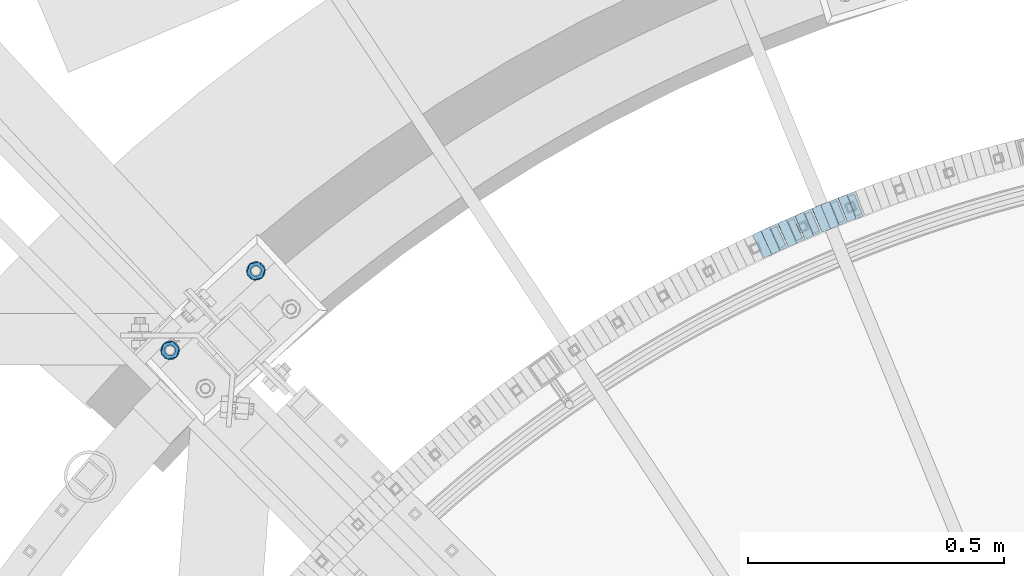
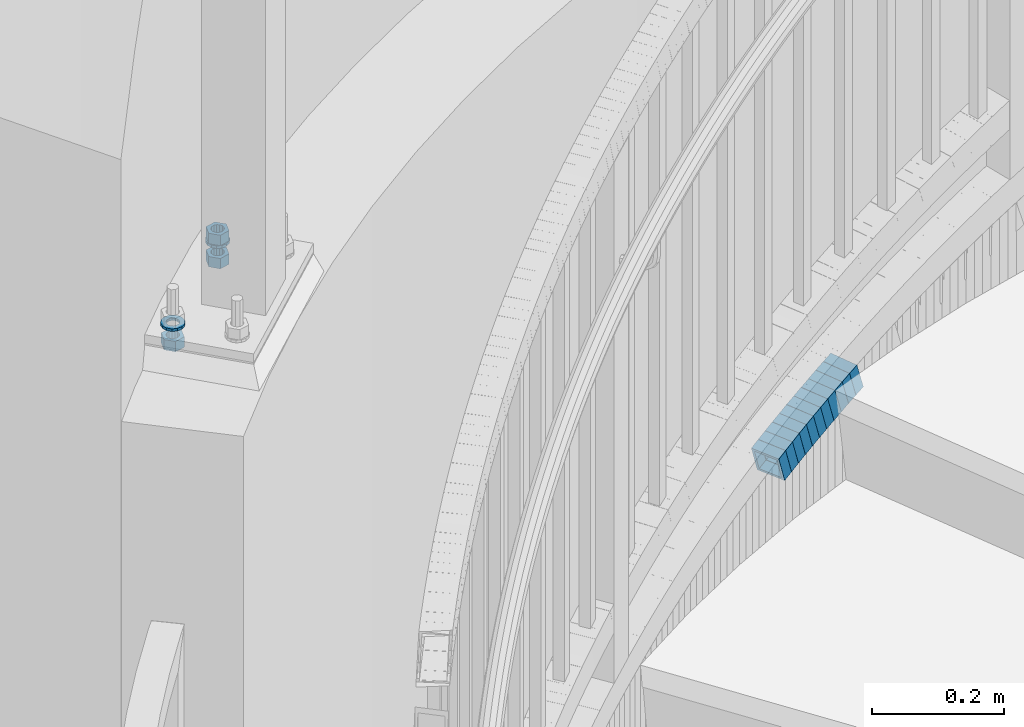
# One storey, part 742 of 975: 16 beams.
"""IFC2X3 building model written with IfcOpenShell, lengths in millimetres."""

import ifcopenshell
import ifcopenshell.guid

model = None  # the IFC model being written
_history = None  # IfcOwnerHistory: only IFC2X3 demands one
_inside = {}  # id of a spatial element -> (the spatial element, [elements in it])
_under = {}  # id of a project, library or spatial element -> (it, [spatial elements below it])
_declared = {}  # id of a project -> (the project, [libraries it declares])
_typed = {}  # id of a type object -> (the type object, [elements of that type])
_made_of = {}  # id of a material, layer set ... -> (it, [elements and type objects made of it])


def new_model(schema):
    """Start an empty IFC model of exactly this schema.

    Asked for "IFC4X3", IfcOpenShell would pick the latest addendum, in which some entities
    have other attributes; the version numbers below select the first issue.
    IFC2X3 requires an IfcOwnerHistory on every rooted entity: one is made here for all.
    """
    global model, _history
    if schema == "IFC4X3":
        model = ifcopenshell.file(schema_version=(4, 3, 0, 0))
    else:
        model = ifcopenshell.file(schema=schema)
    _inside.clear()
    _under.clear()
    _declared.clear()
    _typed.clear()
    _made_of.clear()
    _history = None
    if model.schema == "IFC2X3":
        org = make("IfcOrganization", Name="unknown")
        user = make(
            "IfcPersonAndOrganization",
            ThePerson=make("IfcPerson", FamilyName="unknown"),
            TheOrganization=org,
        )
        app = make(
            "IfcApplication",
            ApplicationDeveloper=org,
            Version="unknown",
            ApplicationFullName="unknown",
            ApplicationIdentifier="unknown",
        )
        _history = make(
            "IfcOwnerHistory",
            OwningUser=user,
            OwningApplication=app,
            ChangeAction="ADDED",
            CreationDate=0,
        )
    return model


def make(cls, **values):
    """One entity of the class cls with the attributes given. An attribute that is None is left unset."""
    return model.create_entity(
        cls, **{name: value for name, value in values.items() if value is not None}
    )


def rooted(cls, **values):
    """An entity with a GlobalId (a new one), such as an element, a storey or a relation."""
    return make(cls, GlobalId=ifcopenshell.guid.new(), OwnerHistory=_history, **values)


def si_unit(unit_type, name, prefix=None):
    """IfcSIUnit, for example si_unit("LENGTHUNIT", "METRE", prefix="MILLI")."""
    return make("IfcSIUnit", UnitType=unit_type, Prefix=prefix, Name=name)


def assignment(units):
    """IfcUnitAssignment: the units of a project."""
    return None if units is None else make("IfcUnitAssignment", Units=units)


def point(xyz):
    """IfcCartesianPoint."""
    return None if xyz is None else make("IfcCartesianPoint", Coordinates=xyz)


def direction(xyz):
    """IfcDirection."""
    return None if xyz is None else make("IfcDirection", DirectionRatios=xyz)


def frame(location, z_axis=None, x_axis=None):
    """IfcAxis2Placement3D, a coordinate frame: its origin and axes. An axis left out is left unset."""
    return make(
        "IfcAxis2Placement3D",
        Location=point(location),
        Axis=direction(z_axis),
        RefDirection=direction(x_axis),
    )


def origin_with_axes():
    """The frame at (0, 0, 0) with the z axis (0, 0, 1) and the x axis (1, 0, 0) written out."""
    return frame((0.0, 0.0, 0.0), z_axis=(0.0, 0.0, 1.0), x_axis=(1.0, 0.0, 0.0))


def place(relative_to, where):
    """IfcLocalPlacement: puts the frame where relative to a parent placement (None: the world)."""
    return make(
        "IfcLocalPlacement", PlacementRelTo=relative_to, RelativePlacement=where
    )


def context(
    kind, dimensions, precision=None, world=None, true_north=None, identifier=None
):
    """IfcGeometricRepresentationContext, for example the 3D "Model" context."""
    return make(
        "IfcGeometricRepresentationContext",
        ContextIdentifier=identifier,
        ContextType=kind,
        CoordinateSpaceDimension=dimensions,
        Precision=precision,
        WorldCoordinateSystem=world,
        TrueNorth=true_north,
    )


def subcontext(parent, identifier, kind, view, scale=None):
    """IfcGeometricRepresentationSubContext, for example "Body" below "Model"."""
    return make(
        "IfcGeometricRepresentationSubContext",
        ContextIdentifier=identifier,
        ContextType=kind,
        ParentContext=parent,
        TargetScale=scale,
        TargetView=view,
    )


def project(units=None, contexts=None):
    """IfcProject with its units and contexts."""
    return rooted(
        "IfcProject",
        Name="project",
        RepresentationContexts=contexts,
        UnitsInContext=assignment(units),
    )


def spatial(cls, under=None, at=None, **own):
    """A site, building, storey or space (cls), placed at a placement, below another one or the project."""
    s = rooted(cls, ObjectPlacement=at, **own)
    if under is not None:
        _under.setdefault(under.id(), (under, []))[1].append(s)
    return s


def faces_of(points, faces, orient=None, outer=None):
    """IfcFace entities. A face is a list of loops; a loop is a list of indices into points, from 0.

    orient and outer hold one flag for each loop. By default every Orientation is true, the
    first loop of a face is its IfcFaceOuterBound and the others are IfcFaceBound.
    """
    made = []
    for i, loops in enumerate(faces):
        bounds = []
        for j, loop in enumerate(loops):
            is_outer = j == 0 if outer is None else outer[i][j]
            bounds.append(
                make(
                    "IfcFaceOuterBound" if is_outer else "IfcFaceBound",
                    Bound=make("IfcPolyLoop", Polygon=[points[k] for k in loop]),
                    Orientation=True if orient is None else orient[i][j],
                )
            )
        made.append(make("IfcFace", Bounds=bounds))
    return made


def faceted_brep(points, faces, orient=None, outer=None, voids=None):
    """IfcFacetedBrep: a solid bounded by flat faces; with voids (closed shells), ...WithVoids."""
    shared = [point(p) for p in points]
    hull = make("IfcClosedShell", CfsFaces=faces_of(shared, faces, orient, outer))
    if voids is None:
        return make("IfcFacetedBrep", Outer=hull)
    return make(
        "IfcFacetedBrepWithVoids",
        Outer=hull,
        Voids=[
            make(cls, CfsFaces=faces_of(shared, fs, o, b)) for cls, fs, o, b in voids
        ],
    )


def shape(context_of_items, identifier, shape_type, items):
    """IfcShapeRepresentation: the items that make up one representation, for example the "Body"."""
    return make(
        "IfcShapeRepresentation",
        ContextOfItems=context_of_items,
        RepresentationIdentifier=identifier,
        RepresentationType=shape_type,
        Items=items,
    )


def material(Name=None, Category=None):
    """IfcMaterial."""
    return make("IfcMaterial", Name=Name, Category=Category)


def made_of(thing, what):
    """Note that an element or type object is made of a material, layer set ...; save() writes the relation."""
    if what is not None:
        _made_of.setdefault(what.id(), (what, []))[1].append(thing)
    return thing


def type_object(cls, material=None, **own):
    """A type object (cls), such as IfcWallType, which elements share."""
    return made_of(rooted(cls, **own), material)


def element(
    cls,
    number,
    at=None,
    inside=None,
    cuts=None,
    type_object=None,
    material=None,
    context=None,
    identifier="Body",
    shape_type=None,
    held_by="IfcProductDefinitionShape",
    body=None,
    shapes=None,
    **own,
):
    """One element of the class cls, such as IfcWall. Its Tag is "e" and its number.

    at: its placement. inside: the storey or other place that contains it. cuts: it is an
    opening in that element (IfcRelVoidsElement). A single representation is given by context,
    identifier, shape_type and body (its items); several are given by shapes. held_by: the class
    of the entity that holds the representations. save() writes the other relations.
    """
    e = rooted(cls, Tag="e%d" % number, ObjectPlacement=at, **own)
    if body is not None:
        shapes = [shape(context, identifier, shape_type, body)]
    if shapes is not None:
        e.Representation = make(held_by, Representations=shapes)
    if inside is not None:
        _inside.setdefault(inside.id(), (inside, []))[1].append(e)
    if cuts is not None:
        rooted(
            "IfcRelVoidsElement", RelatingBuildingElement=cuts, RelatedOpeningElement=e
        )
    if type_object is not None:
        _typed.setdefault(type_object.id(), (type_object, []))[1].append(e)
    return made_of(e, material)


def aggregate(whole, parts):
    """IfcRelAggregates: a whole, such as a stair, and the parts it consists of."""
    return rooted("IfcRelAggregates", RelatingObject=whole, RelatedObjects=parts)


def save(model, path):
    """Write the relations noted so far, then the file.

    IfcRelAggregates (storeys below a building ...), IfcRelContainedInSpatialStructure (elements
    in a storey), IfcRelDefinesByType, IfcRelAssociatesMaterial and IfcRelDeclares: one each for
    every whole, place, type object, material and project.
    """
    for whole, parts in _under.values():
        aggregate(whole, parts)
    for where, things in _inside.values():
        rooted(
            "IfcRelContainedInSpatialStructure",
            RelatedElements=things,
            RelatingStructure=where,
        )
    for kind, things in _typed.values():
        rooted("IfcRelDefinesByType", RelatedObjects=things, RelatingType=kind)
    for what, things in _made_of.values():
        rooted("IfcRelAssociatesMaterial", RelatedObjects=things, RelatingMaterial=what)
    for by, libraries in _declared.values():
        rooted("IfcRelDeclares", RelatingContext=by, RelatedDefinitions=libraries)
    model.write(path)


model = new_model("IFC2X3")

# Units and contexts
model_context = context("Model", 3, precision=1e-05, world=origin_with_axes())
body_context = subcontext(model_context, "Body", "Model", "MODEL_VIEW")
ifc_project = project(units=[si_unit("LENGTHUNIT", "METRE", prefix="MILLI"), si_unit("AREAUNIT", "SQUARE_METRE"), si_unit("VOLUMEUNIT", "CUBIC_METRE"), si_unit("MASSUNIT", "GRAM", prefix="KILO"), si_unit("TIMEUNIT", "SECOND"), si_unit("PLANEANGLEUNIT", "RADIAN"), si_unit("SOLIDANGLEUNIT", "STERADIAN"), si_unit("THERMODYNAMICTEMPERATUREUNIT", "DEGREE_CELSIUS"), si_unit("LUMINOUSINTENSITYUNIT", "LUMEN")], contexts=[model_context])

# Site, building, storey
site_placement = place(None, origin_with_axes())
site = spatial("IfcSite", under=ifc_project, at=site_placement, CompositionType="ELEMENT")
building_placement = place(site_placement, origin_with_axes())
building = spatial("IfcBuilding", under=site, at=building_placement, Name="Undefined", CompositionType="ELEMENT")
storey_placement = place(building_placement, origin_with_axes())
storey = spatial("IfcBuildingStorey", under=building, at=storey_placement, Name="Undefined", CompositionType="ELEMENT", Elevation=0.0)

# Beams
ifc_material_1 = material()
beam_type_1 = type_object("IfcBeamType", Name="HSS2X2X.188_TUBES", PredefinedType="NOTDEFINED")
beam_1_placement = place(storey_placement, frame((33684.4152739988, 6075.29577214784, 698.497322510695), z_axis=(0.374278314232651, -0.927316420373955, 2.41270754486322e-11), x_axis=(-0.883603947282883, -0.356635328114114, -0.303406175097091)))
element("IfcBeam", 1, at=beam_1_placement, inside=storey, type_object=beam_type_1, material=ifc_material_1, Name="WALL", ObjectType="HSS2X2X.188_TUBES", context=body_context, shape_type="Brep", body=[
    faceted_brep([(0.0, 20.6374999999753, -20.6375000000298), (0.0, -20.6375000000153, -20.6375000000153), (18.7853666454903, -20.6375000000535, -20.6375000000326), (18.785366645363, 20.6374999999862, -20.6375000000044), (0.0, -20.6374999999825, 20.6375000000335), (18.785366645352, -20.6375000000007, 20.6374999999989), (0.0, 20.6375000000116, 20.6375000000189), (18.7853666453102, 20.6375000000025, 20.6374999999753), (0.0, 25.3999999999724, -25.4000000000342), (0.0, 25.400000000016, 25.4000000000196), (18.7853666452065, 25.4000000000451, 25.4000000000351), (18.7853666453739, 25.3999999999833, -25.400000000006), (0.0, -25.399999999976, 25.4000000000378), (18.7853666497213, -25.399999993424, 25.3999999995158), (0.0, -25.400000000016, -25.4000000000196), (18.7853666455194, -25.4000000000633, -25.4000000000406)], [[[0, 1, 2, 3]], [[1, 4, 5, 2]], [[4, 6, 7, 5]], [[6, 0, 3, 7]], [[8, 9, 10, 11]], [[9, 12, 13, 10]], [[12, 14, 15, 13]], [[14, 8, 11, 15]], [[13, 15, 11, 10], [5, 7, 3, 2]], [[14, 12, 9, 8], [6, 4, 1, 0]]]),
])
beam_2_placement = place(storey_placement, frame((33701.4372815012, 6081.82035562376, 704.194928636222), z_axis=(0.362715533424743, -0.931899909760916, -1.45439344123588e-10), x_axis=(-0.888059205870413, -0.345651786949592, -0.303110027955799)))
element("IfcBeam", 2, at=beam_2_placement, inside=storey, type_object=beam_type_1, material=ifc_material_1, Name="WALL", ObjectType="HSS2X2X.188_TUBES", context=body_context, shape_type="Brep", body=[
    faceted_brep([(0.0, 20.6374999999753, -20.6375000000298), (0.0, -20.6375000000153, -20.6375000000153), (18.8066477608099, -20.6374999999862, -20.6375000000116), (18.8066477608172, 20.6375000000062, -20.6374999999971), (0.0, -20.6374999999825, 20.6375000000335), (18.8066477608463, -20.6375000000062, 20.6375000000407), (0.0, 20.6375000000116, 20.6375000000189), (18.8066477608536, 20.6374999999844, 20.637500000048), (0.0, 25.3999999999724, -25.4000000000342), (0.0, 25.400000000016, 25.4000000000196), (18.8066477608591, 25.3999999999814, 25.400000000056), (18.8066477608154, 25.4000000000051, -25.4000000000015), (0.0, -25.399999999976, 25.4000000000378), (18.8066477608518, -25.4000000000087, 25.4000000000451), (0.0, -25.400000000016, -25.4000000000196), (18.8066477608081, -25.3999999999851, -25.4000000000196)], [[[0, 1, 2, 3]], [[1, 4, 5, 2]], [[4, 6, 7, 5]], [[6, 0, 3, 7]], [[8, 9, 10, 11]], [[9, 12, 13, 10]], [[12, 14, 15, 13]], [[14, 8, 11, 15]], [[13, 15, 11, 10], [5, 7, 3, 2]], [[14, 12, 9, 8], [6, 4, 1, 0]]]),
])
for number, where, z_axis, x_axis, name in (
    (3, (33651.1781848569, 6061.82399622755, 687.031840070011), (0.379066925584048, -0.925369259230205, -2.88005594484275e-10), (-0.880491033946497, -0.360683073978141, -0.307641445981368), "WALL"),
    (4, (33667.77818525, 6068.6239961446, 692.831839940135), (0.379066925584048, -0.925369259230205, -2.88005594484275e-10), (-0.880491033946497, -0.360683073978141, -0.307641445981368), "WALL"),
):
    element("IfcBeam", number, at=place(storey_placement, frame(where, z_axis=z_axis, x_axis=x_axis)), inside=storey, type_object=beam_type_1, material=ifc_material_1, Name=name, ObjectType="HSS2X2X.188_TUBES", context=body_context, shape_type="Brep", body=[
        faceted_brep([(0.0, 20.6374999999753, -20.6375000000298), (0.0, -20.6375000000153, -20.6375000000153), (18.8480768248774, -20.6374999999716, -20.6375000000735), (18.8480768249356, 20.6375000000153, -20.6375000000226), (0.0, -20.6374999999825, 20.6375000000335), (18.8480768249283, -20.6374999999935, 20.6374999999716), (0.0, 20.6375000000116, 20.6375000000189), (18.8480768249865, 20.6374999999935, 20.6375000000262), (0.0, 25.3999999999724, -25.4000000000342), (0.0, 25.400000000016, 25.4000000000196), (18.848076825001, 25.3999999999887, 25.4000000000378), (18.8480768249392, 25.4000000000142, -25.4000000000233), (0.0, -25.399999999976, 25.4000000000378), (18.8480768249283, -25.399999999996, 25.3999999999833), (0.0, -25.400000000016, -25.4000000000196), (18.8480768248664, -25.3999999999687, -25.4000000000779)], [[[0, 1, 2, 3]], [[1, 4, 5, 2]], [[4, 6, 7, 5]], [[6, 0, 3, 7]], [[8, 9, 10, 11]], [[9, 12, 13, 10]], [[12, 14, 15, 13]], [[14, 8, 11, 15]], [[13, 15, 11, 10], [5, 7, 3, 2]], [[14, 12, 9, 8], [6, 4, 1, 0]]]),
    ])
beam_3_placement = place(storey_placement, frame((33634.1420496722, 6054.94670386387, 681.194547889136), z_axis=(0.390549846936672, -0.920581781841104, 1.1943939171033e-12), x_axis=(-0.877287332469956, -0.37218250477514, -0.303062896816902)))
element("IfcBeam", 5, at=beam_3_placement, inside=storey, type_object=beam_type_1, material=ifc_material_1, Name="WALL", ObjectType="HSS2X2X.188_TUBES", context=body_context, shape_type="Brep", body=[
    faceted_brep([(0.0, 20.6374999999753, -20.6375000000298), (0.0, -20.6375000000153, -20.6375000000153), (18.8066477608099, -20.6374999999862, -20.6375000000116), (18.8066477608172, 20.6375000000062, -20.6374999999971), (0.0, -20.6374999999825, 20.6375000000335), (18.8066477608463, -20.6375000000062, 20.6375000000407), (0.0, 20.6375000000116, 20.6375000000189), (18.8066477608536, 20.6374999999844, 20.637500000048), (0.0, 25.3999999999724, -25.4000000000342), (0.0, 25.400000000016, 25.4000000000196), (18.8066477608591, 25.3999999999814, 25.400000000056), (18.8066477608154, 25.4000000000051, -25.4000000000015), (0.0, -25.399999999976, 25.4000000000378), (18.8066477608518, -25.4000000000087, 25.4000000000451), (0.0, -25.400000000016, -25.4000000000196), (18.8066477608081, -25.3999999999851, -25.4000000000196)], [[[0, 1, 2, 3]], [[1, 4, 5, 2]], [[4, 6, 7, 5]], [[6, 0, 3, 7]], [[8, 9, 10, 11]], [[9, 12, 13, 10]], [[12, 14, 15, 13]], [[14, 8, 11, 15]], [[13, 15, 11, 10], [5, 7, 3, 2]], [[14, 12, 9, 8], [6, 4, 1, 0]]]),
])
beam_4_placement = place(storey_placement, frame((33600.9300295219, 6040.9605270002, 669.835404358529), z_axis=(0.401990062357494, -0.915644030049788, -1.95609572983813e-10), x_axis=(-0.871108966777079, -0.382438082902106, -0.308075121921151)))
element("IfcBeam", 6, at=beam_4_placement, inside=storey, type_object=beam_type_1, material=ifc_material_1, Name="WALL", ObjectType="HSS2X2X.188_TUBES", context=body_context, shape_type="Brep", body=[
    faceted_brep([(0.0, 20.6374999999753, -20.6375000000298), (0.0, -20.6375000000153, -20.6375000000153), (18.8332159191086, -20.6374999999916, -20.6375000000153), (18.8332159190923, 20.6375000000062, -20.6375000000335), (0.0, -20.6374999999825, 20.6375000000335), (18.8332159191377, -20.6375000000062, 20.6375000000335), (0.0, 20.6375000000116, 20.6375000000189), (18.8332159191141, 20.6374999999916, 20.6375000000116), (0.0, 25.3999999999724, -25.4000000000342), (0.0, 25.400000000016, 25.4000000000196), (18.8332159191159, 25.3999999999905, 25.4000000000124), (18.8332159190886, 25.4000000000069, -25.4000000000415), (0.0, -25.399999999976, 25.4000000000378), (18.8332159191395, -25.4000000000069, 25.4000000000378), (0.0, -25.400000000016, -25.4000000000196), (18.8332159191104, -25.3999999999905, -25.400000000016)], [[[0, 1, 2, 3]], [[1, 4, 5, 2]], [[4, 6, 7, 5]], [[6, 0, 3, 7]], [[8, 9, 10, 11]], [[9, 12, 13, 10]], [[12, 14, 15, 13]], [[14, 8, 11, 15]], [[13, 15, 11, 10], [5, 7, 3, 2]], [[14, 12, 9, 8], [6, 4, 1, 0]]]),
])
beam_5_placement = place(storey_placement, frame((33617.6420496722, 6047.94670386386, 675.494547889179), z_axis=(0.390549846936672, -0.920581781841104, 1.1943939171033e-12), x_axis=(-0.877287332469956, -0.37218250477514, -0.303062896816902)))
element("IfcBeam", 7, at=beam_5_placement, inside=storey, type_object=beam_type_1, material=ifc_material_1, Name="WALL", ObjectType="HSS2X2X.188_TUBES", context=body_context, shape_type="Brep", body=[
    faceted_brep([(0.0, 20.6374999999753, -20.6375000000298), (0.0, -20.6375000000153, -20.6375000000153), (18.8066477608099, -20.6374999999862, -20.6375000000116), (18.8066477608172, 20.6375000000062, -20.6374999999971), (0.0, -20.6374999999825, 20.6375000000335), (18.8066477608463, -20.6375000000062, 20.6375000000407), (0.0, 20.6375000000116, 20.6375000000189), (18.8066477608536, 20.6374999999844, 20.637500000048), (0.0, 25.3999999999724, -25.4000000000342), (0.0, 25.400000000016, 25.4000000000196), (18.8066477608591, 25.3999999999814, 25.400000000056), (18.8066477608154, 25.4000000000051, -25.4000000000015), (0.0, -25.399999999976, 25.4000000000378), (18.8066477608518, -25.4000000000087, 25.4000000000451), (0.0, -25.400000000016, -25.4000000000196), (18.8066477608081, -25.3999999999851, -25.4000000000196)], [[[0, 1, 2, 3]], [[1, 4, 5, 2]], [[4, 6, 7, 5]], [[6, 0, 3, 7]], [[8, 9, 10, 11]], [[9, 12, 13, 10]], [[12, 14, 15, 13]], [[14, 8, 11, 15]], [[13, 15, 11, 10], [5, 7, 3, 2]], [[14, 12, 9, 8], [6, 4, 1, 0]]]),
])
beam_6_placement = place(storey_placement, frame((33584.4179459107, 6033.71131956114, 663.996107028624), z_axis=(0.401990062357494, -0.915644030049788, -1.95609572983813e-10), x_axis=(-0.872525595308091, -0.38306001713522, -0.303255847107069)))
element("IfcBeam", 8, at=beam_6_placement, inside=storey, type_object=beam_type_1, material=ifc_material_1, Name="WALL", ObjectType="HSS2X2X.188_TUBES", context=body_context, shape_type="Brep", body=[
    faceted_brep([(0.0, 20.6374999999753, -20.6375000000298), (0.0, -20.6375000000153, -20.6375000000153), (18.8047866246379, -20.6374999999916, -20.6375000000298), (18.8047866247143, 20.6374999999844, -20.6374999999643), (0.0, -20.6374999999825, 20.6375000000335), (18.8047866247107, -20.6375000000189, 20.6375000000407), (0.0, 20.6375000000116, 20.6375000000189), (18.8047866247907, 20.6374999999589, 20.6375000001026), (0.0, 25.3999999999724, -25.4000000000342), (0.0, 25.400000000016, 25.4000000000196), (18.8047866248016, 25.3999999999542, 25.4000000001142), (18.8047866247143, 25.3999999999851, -25.3999999999651), (0.0, -25.399999999976, 25.4000000000378), (18.8047866247107, -25.4000000000196, 25.4000000000415), (0.0, -25.400000000016, -25.4000000000196), (18.8047866246197, -25.3999999999887, -25.4000000000378)], [[[0, 1, 2, 3]], [[1, 4, 5, 2]], [[4, 6, 7, 5]], [[6, 0, 3, 7]], [[8, 9, 10, 11]], [[9, 12, 13, 10]], [[12, 14, 15, 13]], [[14, 8, 11, 15]], [[13, 15, 11, 10], [5, 7, 3, 2]], [[14, 12, 9, 8], [6, 4, 1, 0]]]),
])
beam_7_placement = place(storey_placement, frame((33567.804393245, 6026.52207555159, 658.33665674057), z_axis=(0.413382019133395, -0.910557689691981, 8.06111302154023e-11), x_axis=(-0.866225119080296, -0.393255576036546, -0.308227343028635)))
element("IfcBeam", 9, at=beam_7_placement, inside=storey, type_object=beam_type_1, material=ifc_material_1, Name="WALL", ObjectType="HSS2X2X.188_TUBES", context=body_context, shape_type="Brep", body=[
    faceted_brep([(0.0, 20.6374999999753, -20.6375000000298), (0.0, -20.6375000000153, -20.6375000000153), (18.8225928075335, -20.6374999999935, -20.6375000000298), (18.8225928075699, 20.6374999999898, -20.6374999999825), (0.0, -20.6374999999825, 20.6375000000335), (18.8225928075772, -20.637500000008, 20.6375000000226), (0.0, 20.6375000000116, 20.6375000000189), (18.8225928076135, 20.6374999999753, 20.6375000000698), (0.0, 25.3999999999724, -25.4000000000342), (0.0, 25.400000000016, 25.4000000000196), (18.8225928076281, 25.3999999999705, 25.4000000000815), (18.8225928075663, 25.3999999999905, -25.3999999999796), (0.0, -25.399999999976, 25.4000000000378), (18.8225928075808, -25.4000000000087, 25.4000000000233), (0.0, -25.400000000016, -25.4000000000196), (18.8225928075226, -25.3999999999905, -25.4000000000378)], [[[0, 1, 2, 3]], [[1, 4, 5, 2]], [[4, 6, 7, 5]], [[6, 0, 3, 7]], [[8, 9, 10, 11]], [[9, 12, 13, 10]], [[12, 14, 15, 13]], [[14, 8, 11, 15]], [[13, 15, 11, 10], [5, 7, 3, 2]], [[14, 12, 9, 8], [6, 4, 1, 0]]]),
])
beam_8_placement = place(storey_placement, frame((33534.8670422555, 6011.62707264035, 646.798192227203), z_axis=(0.424720211576408, -0.905324661035195, -3.22928826790303e-10), x_axis=(-0.862617851630733, -0.404684917826769, -0.303513688870074)))
element("IfcBeam", 10, at=beam_8_placement, inside=storey, type_object=beam_type_1, material=ifc_material_1, Name="WALL", ObjectType="HSS2X2X.188_TUBES", context=body_context, shape_type="Brep", body=[
    faceted_brep([(0.0, 20.6374999999753, -20.6375000000298), (0.0, -20.6375000000153, -20.6375000000153), (18.7771137292038, -20.637500000008, -20.6374999999862), (18.777113729182, 20.6375000000062, -20.6375000000189), (0.0, -20.6374999999825, 20.6375000000335), (18.7771137291729, -20.6374999999916, 20.6374999999753), (0.0, 20.6375000000116, 20.6375000000189), (18.7771137291529, 20.6375000000207, 20.6374999999389), (0.0, 25.3999999999724, -25.4000000000342), (0.0, 25.400000000016, 25.4000000000196), (18.7771137291475, 25.4000000000251, 25.3999999999287), (18.7771137291857, 25.4000000000051, -25.4000000000196), (0.0, -25.399999999976, 25.4000000000378), (18.7771137291711, -25.3999999999905, 25.3999999999724), (0.0, -25.400000000016, -25.4000000000196), (18.7771137292129, -25.4000000000124, -25.3999999999724)], [[[0, 1, 2, 3]], [[1, 4, 5, 2]], [[4, 6, 7, 5]], [[6, 0, 3, 7]], [[8, 9, 10, 11]], [[9, 12, 13, 10]], [[12, 14, 15, 13]], [[14, 8, 11, 15]], [[13, 15, 11, 10], [5, 7, 3, 2]], [[14, 12, 9, 8], [6, 4, 1, 0]]]),
])
beam_9_placement = place(storey_placement, frame((33551.3643209831, 6019.07814465863, 652.508728300403), z_axis=(0.415494357589312, -0.909595755713188, 1.62834112416022e-10), x_axis=(-0.866310160426214, -0.395721925194677, -0.304812834149951)))
element("IfcBeam", 11, at=beam_9_placement, inside=storey, type_object=beam_type_1, material=ifc_material_1, Name="WALL", ObjectType="HSS2X2X.188_TUBES", context=body_context, shape_type="Brep", body=[
    faceted_brep([(0.0, 20.6374999999753, -20.6375000000298), (0.0, -20.6375000000153, -20.6375000000153), (18.6959888745805, -20.6374999999771, -20.6375000000407), (18.6959888746751, 20.637499999988, -20.6374999999716), (0.0, -20.6374999999825, 20.6375000000335), (18.6959888746969, -20.6375000000135, 20.6375000000371), (0.0, 20.6375000000116, 20.6375000000189), (18.6959888747988, 20.6374999999498, 20.6375000001062), (0.0, 25.3999999999724, -25.4000000000342), (0.0, 25.400000000016, 25.4000000000196), (18.695988874817, 25.3999999999414, 25.4000000001215), (18.6959888746678, 25.3999999999887, -25.399999999976), (0.0, -25.399999999976, 25.4000000000378), (18.6959888747042, -25.4000000000124, 25.4000000000378), (0.0, -25.400000000016, -25.4000000000196), (18.695988874555, -25.3999999999687, -25.4000000000597)], [[[0, 1, 2, 3]], [[1, 4, 5, 2]], [[4, 6, 7, 5]], [[6, 0, 3, 7]], [[8, 9, 10, 11]], [[9, 12, 13, 10]], [[12, 14, 15, 13]], [[14, 8, 11, 15]], [[13, 15, 11, 10], [5, 7, 3, 2]], [[14, 12, 9, 8], [6, 4, 1, 0]]]),
])
ifc_material_2 = material(Name="STEEL/A36")
beam_type_2 = type_object("IfcBeamType", Name="3/4_WASHER", PredefinedType="NOTDEFINED")
beam_10_placement = place(storey_placement, frame((32362.2356149595, 5798.05138456451, 1433.5125), z_axis=(-0.733848438057767, -0.679313234053464, 0.0), x_axis=(0.0, 0.0, -1.0)))
element("IfcBeam", 12, at=beam_10_placement, inside=storey, type_object=beam_type_2, material=ifc_material_2, Name="WASHER", ObjectType="3/4_WASHER", context=body_context, shape_type="Brep", body=[
    faceted_brep([(0.0, -18.6499996185303, 0.0), (0.0, -16.8030690426876, -8.09193156902904), (4.76250000000073, -16.8030690426876, -8.09193156902904), (4.76250000000073, -18.6499996185303, 0.0), (0.0, -11.6280845668225, -14.5811568497838), (4.76250000000073, -11.6280845668225, -14.5811568497838), (0.0, -4.15001533340001, -18.1824051902857), (4.76250000000073, -4.15001533340001, -18.1824051902857), (0.0, 4.15001533340001, -18.1824051902857), (4.76250000000073, 4.15001533340001, -18.1824051902857), (0.0, 11.6280845668234, -14.5811568497838), (4.76250000000073, 11.6280845668234, -14.5811568497838), (0.0, 16.8030690426876, -8.09193156902904), (4.76250000000073, 16.8030690426876, -8.09193156902904), (0.0, 18.6499996185303, 0.0), (4.76250000000073, 18.6499996185303, 0.0), (0.0, 16.8030690426876, 8.09193156902904), (4.76250000000073, 16.8030690426876, 8.09193156902904), (0.0, 11.6280845668225, 14.5811568497838), (4.76250000000073, 11.6280845668225, 14.5811568497838), (0.0, 4.15001533340001, 18.1824051902857), (4.76250000000073, 4.15001533340001, 18.1824051902857), (0.0, -4.15001533340001, 18.1824051902857), (4.76250000000073, -4.15001533340001, 18.1824051902857), (0.0, -11.6280845668234, 14.5811568497838), (4.76250000000073, -11.6280845668234, 14.5811568497838), (0.0, -16.8030690426876, 8.09193156902904), (4.76250000000073, -16.8030690426876, 8.09193156902904), (0.0, 0.0, 10.3199996948242), (0.0, 4.47768005528269, 9.29799844179911), (4.76250000000073, 4.47768005528269, 9.29799844179911), (4.76250000000073, 0.0, 10.3199996948242), (0.0, 8.06850066047446, 6.43441456490817), (4.76250000000073, 8.06850066047446, 6.43441456490817), (0.0, 10.0612557561917, 2.29641597052117), (4.76250000000073, 10.0612557561917, 2.29641597052117), (0.0, 10.0612557561917, -2.29641597052117), (4.76250000000073, 10.0612557561917, -2.29641597052117), (0.0, 8.06850066047446, -6.43441456490814), (4.76250000000073, 8.06850066047446, -6.43441456490814), (0.0, 4.47768005528269, -9.29799844179908), (4.76250000000073, 4.47768005528269, -9.29799844179908), (0.0, 0.0, -10.3199996948242), (4.76250000000073, 0.0, -10.3199996948242), (0.0, -4.47768005528269, -9.29799844179911), (4.76250000000073, -4.47768005528269, -9.29799844179911), (0.0, -8.06850066047446, -6.43441456490817), (4.76250000000073, -8.06850066047446, -6.43441456490817), (0.0, -10.0612557561917, -2.29641597052117), (4.76250000000073, -10.0612557561917, -2.29641597052117), (0.0, -10.0612557561917, 2.29641597052117), (4.76250000000073, -10.0612557561917, 2.29641597052117), (0.0, -8.06850066047446, 6.43441456490814), (4.76250000000073, -8.06850066047446, 6.43441456490814), (0.0, -4.47768005528269, 9.29799844179908), (4.76250000000073, -4.47768005528269, 9.29799844179908)], [[[0, 1, 2, 3]], [[1, 4, 5, 2]], [[4, 6, 7, 5]], [[6, 8, 9, 7]], [[8, 10, 11, 9]], [[10, 12, 13, 11]], [[12, 14, 15, 13]], [[14, 16, 17, 15]], [[16, 18, 19, 17]], [[18, 20, 21, 19]], [[20, 22, 23, 21]], [[22, 24, 25, 23]], [[24, 26, 27, 25]], [[26, 0, 3, 27]], [[28, 29, 30, 31]], [[29, 32, 33, 30]], [[32, 34, 35, 33]], [[34, 36, 37, 35]], [[36, 38, 39, 37]], [[38, 40, 41, 39]], [[40, 42, 43, 41]], [[42, 44, 45, 43]], [[44, 46, 47, 45]], [[46, 48, 49, 47]], [[48, 50, 51, 49]], [[50, 52, 53, 51]], [[52, 54, 55, 53]], [[54, 28, 31, 55]], [[5, 7, 9, 11, 13, 15, 17, 19, 21, 23, 25, 27, 3, 2], [33, 35, 37, 39, 41, 43, 45, 47, 49, 51, 53, 55, 31, 30]], [[26, 24, 22, 20, 18, 16, 14, 12, 10, 8, 6, 4, 1, 0], [54, 52, 50, 48, 46, 44, 42, 40, 38, 36, 34, 32, 29, 28]]]),
])
beam_11_placement = place(storey_placement, frame((32529.9933678984, 5953.34238986852, 1433.5125), z_axis=(-0.733848438057767, -0.679313234053464, 0.0), x_axis=(0.0, 0.0, -1.0)))
element("IfcBeam", 13, at=beam_11_placement, inside=storey, type_object=beam_type_2, material=ifc_material_2, Name="WASHER", ObjectType="3/4_WASHER", context=body_context, shape_type="Brep", body=[
    faceted_brep([(0.0, -18.6499996185303, 0.0), (0.0, -16.8030690426876, -8.09193156902904), (4.76250000000073, -16.8030690426876, -8.09193156902904), (4.76250000000073, -18.6499996185303, 0.0), (0.0, -11.6280845668225, -14.5811568497838), (4.76250000000073, -11.6280845668225, -14.5811568497838), (0.0, -4.15001533340001, -18.1824051902857), (4.76250000000073, -4.15001533340001, -18.1824051902857), (0.0, 4.15001533340001, -18.1824051902857), (4.76250000000073, 4.15001533340001, -18.1824051902857), (0.0, 11.6280845668234, -14.5811568497838), (4.76250000000073, 11.6280845668234, -14.5811568497838), (0.0, 16.8030690426876, -8.09193156902904), (4.76250000000073, 16.8030690426876, -8.09193156902904), (0.0, 18.6499996185303, 0.0), (4.76250000000073, 18.6499996185303, 0.0), (0.0, 16.8030690426876, 8.09193156902904), (4.76250000000073, 16.8030690426876, 8.09193156902904), (0.0, 11.6280845668225, 14.5811568497838), (4.76250000000073, 11.6280845668225, 14.5811568497838), (0.0, 4.15001533340001, 18.1824051902857), (4.76250000000073, 4.15001533340001, 18.1824051902857), (0.0, -4.15001533340001, 18.1824051902857), (4.76250000000073, -4.15001533340001, 18.1824051902857), (0.0, -11.6280845668234, 14.5811568497838), (4.76250000000073, -11.6280845668234, 14.5811568497838), (0.0, -16.8030690426876, 8.09193156902904), (4.76250000000073, -16.8030690426876, 8.09193156902904), (0.0, 0.0, 10.3199996948242), (0.0, 4.47768005528269, 9.29799844179911), (4.76250000000073, 4.47768005528269, 9.29799844179911), (4.76250000000073, 0.0, 10.3199996948242), (0.0, 8.06850066047446, 6.43441456490817), (4.76250000000073, 8.06850066047446, 6.43441456490817), (0.0, 10.0612557561917, 2.29641597052117), (4.76250000000073, 10.0612557561917, 2.29641597052117), (0.0, 10.0612557561917, -2.29641597052117), (4.76250000000073, 10.0612557561917, -2.29641597052117), (0.0, 8.06850066047446, -6.43441456490814), (4.76250000000073, 8.06850066047446, -6.43441456490814), (0.0, 4.47768005528269, -9.29799844179908), (4.76250000000073, 4.47768005528269, -9.29799844179908), (0.0, 0.0, -10.3199996948242), (4.76250000000073, 0.0, -10.3199996948242), (0.0, -4.47768005528269, -9.29799844179911), (4.76250000000073, -4.47768005528269, -9.29799844179911), (0.0, -8.06850066047446, -6.43441456490817), (4.76250000000073, -8.06850066047446, -6.43441456490817), (0.0, -10.0612557561917, -2.29641597052117), (4.76250000000073, -10.0612557561917, -2.29641597052117), (0.0, -10.0612557561917, 2.29641597052117), (4.76250000000073, -10.0612557561917, 2.29641597052117), (0.0, -8.06850066047446, 6.43441456490814), (4.76250000000073, -8.06850066047446, 6.43441456490814), (0.0, -4.47768005528269, 9.29799844179908), (4.76250000000073, -4.47768005528269, 9.29799844179908)], [[[0, 1, 2, 3]], [[1, 4, 5, 2]], [[4, 6, 7, 5]], [[6, 8, 9, 7]], [[8, 10, 11, 9]], [[10, 12, 13, 11]], [[12, 14, 15, 13]], [[14, 16, 17, 15]], [[16, 18, 19, 17]], [[18, 20, 21, 19]], [[20, 22, 23, 21]], [[22, 24, 25, 23]], [[24, 26, 27, 25]], [[26, 0, 3, 27]], [[28, 29, 30, 31]], [[29, 32, 33, 30]], [[32, 34, 35, 33]], [[34, 36, 37, 35]], [[36, 38, 39, 37]], [[38, 40, 41, 39]], [[40, 42, 43, 41]], [[42, 44, 45, 43]], [[44, 46, 47, 45]], [[46, 48, 49, 47]], [[48, 50, 51, 49]], [[50, 52, 53, 51]], [[52, 54, 55, 53]], [[54, 28, 31, 55]], [[5, 7, 9, 11, 13, 15, 17, 19, 21, 23, 25, 27, 3, 2], [33, 35, 37, 39, 41, 43, 45, 47, 49, 51, 53, 55, 31, 30]], [[26, 24, 22, 20, 18, 16, 14, 12, 10, 8, 6, 4, 1, 0], [54, 52, 50, 48, 46, 44, 42, 40, 38, 36, 34, 32, 29, 28]]]),
])
beam_type_3 = type_object("IfcBeamType", Name="3/4_HEAVY_HEX_NUT", PredefinedType="NOTDEFINED")
beam_12_placement = place(storey_placement, frame((32529.9933678984, 5953.34238986852, 1452.5625), z_axis=(-0.733848438057767, -0.679313234053464, 0.0), x_axis=(0.0, 0.0, -1.0)))
element("IfcBeam", 14, at=beam_12_placement, inside=storey, type_object=beam_type_3, material=ifc_material_2, Name="NUT", ObjectType="3/4_HEAVY_HEX_NUT", context=body_context, shape_type="Brep", body=[
    faceted_brep([(0.0, -18.2600002288818, 0.0), (0.0, -9.13000011444092, -15.8100004196167), (19.0499999999993, -9.13000011444092, -15.8100004196167), (19.0499999999993, -18.2600002288818, 0.0), (0.0, 9.13000011444092, -15.8100004196167), (19.0499999999993, 9.13000011444092, -15.8100004196167), (0.0, 18.2600002288818, 0.0), (19.0499999999993, 18.2600002288818, 0.0), (0.0, 9.13000011444092, 15.8100004196167), (19.0499999999993, 9.13000011444092, 15.8100004196167), (0.0, -9.13000011444092, 15.8100004196167), (19.0499999999993, -9.13000011444092, 15.8100004196167), (0.0, 0.0, 10.3199996948242), (0.0, 4.47768005528269, 9.29799844179911), (19.0499999999993, 4.47768005528269, 9.29799844179911), (19.0499999999993, 0.0, 10.3199996948242), (0.0, 8.06850066047446, 6.43441456490817), (19.0499999999993, 8.06850066047446, 6.43441456490817), (0.0, 10.0612557561917, 2.29641597052117), (19.0499999999993, 10.0612557561917, 2.29641597052117), (0.0, 10.0612557561917, -2.29641597052117), (19.0499999999993, 10.0612557561917, -2.29641597052117), (0.0, 8.06850066047446, -6.43441456490814), (19.0499999999993, 8.06850066047446, -6.43441456490814), (0.0, 4.47768005528269, -9.29799844179908), (19.0499999999993, 4.47768005528269, -9.29799844179908), (0.0, 0.0, -10.3199996948242), (19.0499999999993, 0.0, -10.3199996948242), (0.0, -4.47768005528269, -9.29799844179911), (19.0499999999993, -4.47768005528269, -9.29799844179911), (0.0, -8.06850066047446, -6.43441456490817), (19.0499999999993, -8.06850066047446, -6.43441456490817), (0.0, -10.0612557561917, -2.29641597052117), (19.0499999999993, -10.0612557561917, -2.29641597052117), (0.0, -10.0612557561917, 2.29641597052117), (19.0499999999993, -10.0612557561917, 2.29641597052117), (0.0, -8.06850066047446, 6.43441456490814), (19.0499999999993, -8.06850066047446, 6.43441456490814), (0.0, -4.47768005528269, 9.29799844179908), (19.0499999999993, -4.47768005528269, 9.29799844179908)], [[[0, 1, 2, 3]], [[1, 4, 5, 2]], [[4, 6, 7, 5]], [[6, 8, 9, 7]], [[8, 10, 11, 9]], [[10, 0, 3, 11]], [[12, 13, 14, 15]], [[13, 16, 17, 14]], [[16, 18, 19, 17]], [[18, 20, 21, 19]], [[20, 22, 23, 21]], [[22, 24, 25, 23]], [[24, 26, 27, 25]], [[26, 28, 29, 27]], [[28, 30, 31, 29]], [[30, 32, 33, 31]], [[32, 34, 35, 33]], [[34, 36, 37, 35]], [[36, 38, 39, 37]], [[38, 12, 15, 39]], [[5, 7, 9, 11, 3, 2], [17, 19, 21, 23, 25, 27, 29, 31, 33, 35, 37, 39, 15, 14]], [[10, 8, 6, 4, 1, 0], [38, 36, 34, 32, 30, 28, 26, 24, 22, 20, 18, 16, 13, 12]]]),
])
beam_13_placement = place(storey_placement, frame((32362.2356149595, 5798.05138456451, 1409.7), z_axis=(-0.733848438057767, -0.679313234053464, 0.0), x_axis=(0.0, 0.0, -1.0)))
element("IfcBeam", 15, at=beam_13_placement, inside=storey, type_object=beam_type_3, material=ifc_material_2, Name="NUT", ObjectType="3/4_HEAVY_HEX_NUT", context=body_context, shape_type="Brep", body=[
    faceted_brep([(0.0, -18.2600002288818, 0.0), (0.0, -9.13000011444092, -15.8100004196167), (19.0499999999993, -9.13000011444092, -15.8100004196167), (19.0499999999993, -18.2600002288818, 0.0), (0.0, 9.13000011444092, -15.8100004196167), (19.0499999999993, 9.13000011444092, -15.8100004196167), (0.0, 18.2600002288818, 0.0), (19.0499999999993, 18.2600002288818, 0.0), (0.0, 9.13000011444092, 15.8100004196167), (19.0499999999993, 9.13000011444092, 15.8100004196167), (0.0, -9.13000011444092, 15.8100004196167), (19.0499999999993, -9.13000011444092, 15.8100004196167), (0.0, 0.0, 10.3199996948242), (0.0, 4.47768005528269, 9.29799844179911), (19.0499999999993, 4.47768005528269, 9.29799844179911), (19.0499999999993, 0.0, 10.3199996948242), (0.0, 8.06850066047446, 6.43441456490817), (19.0499999999993, 8.06850066047446, 6.43441456490817), (0.0, 10.0612557561917, 2.29641597052117), (19.0499999999993, 10.0612557561917, 2.29641597052117), (0.0, 10.0612557561917, -2.29641597052117), (19.0499999999993, 10.0612557561917, -2.29641597052117), (0.0, 8.06850066047446, -6.43441456490814), (19.0499999999993, 8.06850066047446, -6.43441456490814), (0.0, 4.47768005528269, -9.29799844179908), (19.0499999999993, 4.47768005528269, -9.29799844179908), (0.0, 0.0, -10.3199996948242), (19.0499999999993, 0.0, -10.3199996948242), (0.0, -4.47768005528269, -9.29799844179911), (19.0499999999993, -4.47768005528269, -9.29799844179911), (0.0, -8.06850066047446, -6.43441456490817), (19.0499999999993, -8.06850066047446, -6.43441456490817), (0.0, -10.0612557561917, -2.29641597052117), (19.0499999999993, -10.0612557561917, -2.29641597052117), (0.0, -10.0612557561917, 2.29641597052117), (19.0499999999993, -10.0612557561917, 2.29641597052117), (0.0, -8.06850066047446, 6.43441456490814), (19.0499999999993, -8.06850066047446, 6.43441456490814), (0.0, -4.47768005528269, 9.29799844179908), (19.0499999999993, -4.47768005528269, 9.29799844179908)], [[[0, 1, 2, 3]], [[1, 4, 5, 2]], [[4, 6, 7, 5]], [[6, 8, 9, 7]], [[8, 10, 11, 9]], [[10, 0, 3, 11]], [[12, 13, 14, 15]], [[13, 16, 17, 14]], [[16, 18, 19, 17]], [[18, 20, 21, 19]], [[20, 22, 23, 21]], [[22, 24, 25, 23]], [[24, 26, 27, 25]], [[26, 28, 29, 27]], [[28, 30, 31, 29]], [[30, 32, 33, 31]], [[32, 34, 35, 33]], [[34, 36, 37, 35]], [[36, 38, 39, 37]], [[38, 12, 15, 39]], [[5, 7, 9, 11, 3, 2], [17, 19, 21, 23, 25, 27, 29, 31, 33, 35, 37, 39, 15, 14]], [[10, 8, 6, 4, 1, 0], [38, 36, 34, 32, 30, 28, 26, 24, 22, 20, 18, 16, 13, 12]]]),
])
beam_14_placement = place(storey_placement, frame((32529.9933678984, 5953.34238986852, 1409.7), z_axis=(-0.733848438057767, -0.679313234053464, 0.0), x_axis=(0.0, 0.0, -1.0)))
element("IfcBeam", 16, at=beam_14_placement, inside=storey, type_object=beam_type_3, material=ifc_material_2, Name="NUT", ObjectType="3/4_HEAVY_HEX_NUT", context=body_context, shape_type="Brep", body=[
    faceted_brep([(0.0, -18.2600002288818, 0.0), (0.0, -9.13000011444092, -15.8100004196167), (19.0499999999993, -9.13000011444092, -15.8100004196167), (19.0499999999993, -18.2600002288818, 0.0), (0.0, 9.13000011444092, -15.8100004196167), (19.0499999999993, 9.13000011444092, -15.8100004196167), (0.0, 18.2600002288818, 0.0), (19.0499999999993, 18.2600002288818, 0.0), (0.0, 9.13000011444092, 15.8100004196167), (19.0499999999993, 9.13000011444092, 15.8100004196167), (0.0, -9.13000011444092, 15.8100004196167), (19.0499999999993, -9.13000011444092, 15.8100004196167), (0.0, 0.0, 10.3199996948242), (0.0, 4.47768005528269, 9.29799844179911), (19.0499999999993, 4.47768005528269, 9.29799844179911), (19.0499999999993, 0.0, 10.3199996948242), (0.0, 8.06850066047446, 6.43441456490817), (19.0499999999993, 8.06850066047446, 6.43441456490817), (0.0, 10.0612557561917, 2.29641597052117), (19.0499999999993, 10.0612557561917, 2.29641597052117), (0.0, 10.0612557561917, -2.29641597052117), (19.0499999999993, 10.0612557561917, -2.29641597052117), (0.0, 8.06850066047446, -6.43441456490814), (19.0499999999993, 8.06850066047446, -6.43441456490814), (0.0, 4.47768005528269, -9.29799844179908), (19.0499999999993, 4.47768005528269, -9.29799844179908), (0.0, 0.0, -10.3199996948242), (19.0499999999993, 0.0, -10.3199996948242), (0.0, -4.47768005528269, -9.29799844179911), (19.0499999999993, -4.47768005528269, -9.29799844179911), (0.0, -8.06850066047446, -6.43441456490817), (19.0499999999993, -8.06850066047446, -6.43441456490817), (0.0, -10.0612557561917, -2.29641597052117), (19.0499999999993, -10.0612557561917, -2.29641597052117), (0.0, -10.0612557561917, 2.29641597052117), (19.0499999999993, -10.0612557561917, 2.29641597052117), (0.0, -8.06850066047446, 6.43441456490814), (19.0499999999993, -8.06850066047446, 6.43441456490814), (0.0, -4.47768005528269, 9.29799844179908), (19.0499999999993, -4.47768005528269, 9.29799844179908)], [[[0, 1, 2, 3]], [[1, 4, 5, 2]], [[4, 6, 7, 5]], [[6, 8, 9, 7]], [[8, 10, 11, 9]], [[10, 0, 3, 11]], [[12, 13, 14, 15]], [[13, 16, 17, 14]], [[16, 18, 19, 17]], [[18, 20, 21, 19]], [[20, 22, 23, 21]], [[22, 24, 25, 23]], [[24, 26, 27, 25]], [[26, 28, 29, 27]], [[28, 30, 31, 29]], [[30, 32, 33, 31]], [[32, 34, 35, 33]], [[34, 36, 37, 35]], [[36, 38, 39, 37]], [[38, 12, 15, 39]], [[5, 7, 9, 11, 3, 2], [17, 19, 21, 23, 25, 27, 29, 31, 33, 35, 37, 39, 15, 14]], [[10, 8, 6, 4, 1, 0], [38, 36, 34, 32, 30, 28, 26, 24, 22, 20, 18, 16, 13, 12]]]),
])

save(model, "model.ifc")
